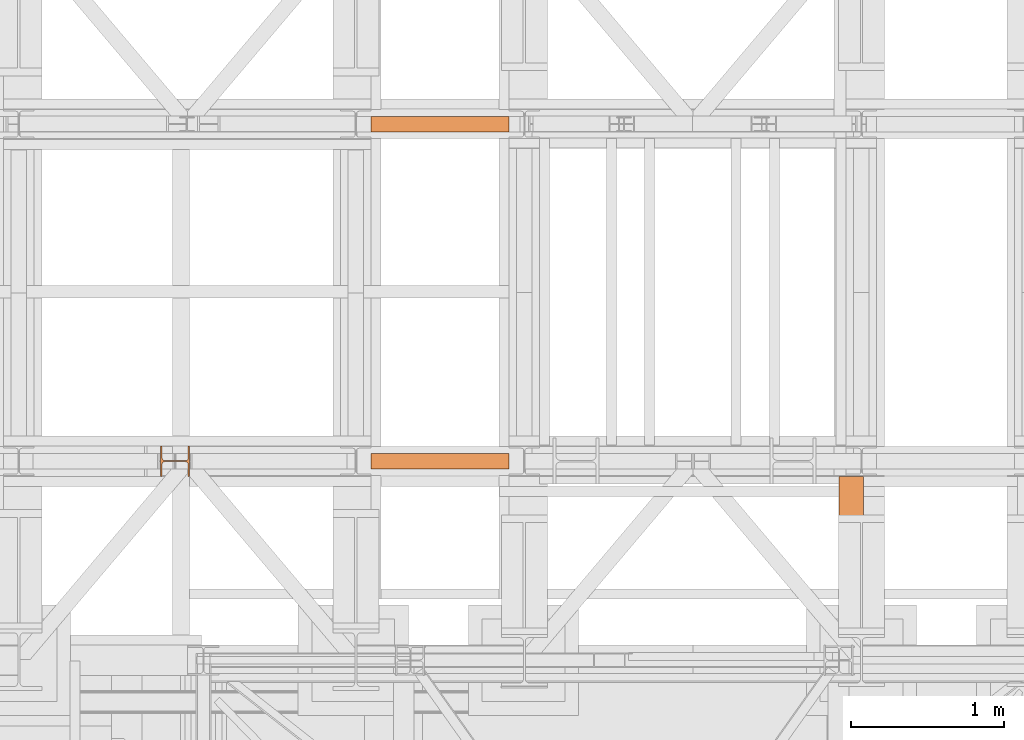
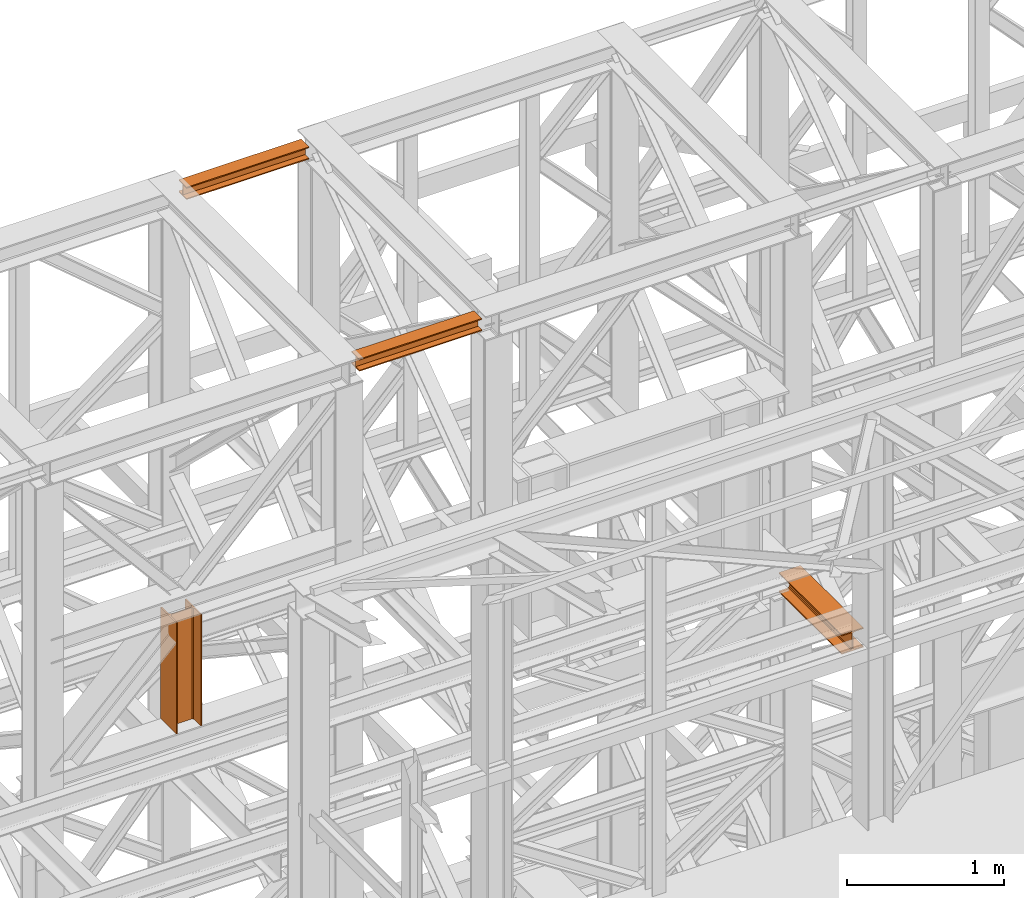
# One storey, part 203 of 208: 4 proxies.
"""IFC2X3 building model written with IfcOpenShell, lengths in millimetres."""

from ifc_helpers import new_model, entity, si_unit, converted_unit, frame, origin, origin_with_axes, place, context, subcontext, project, spatial, faceted_brep, element, save


model = new_model("IFC2X3")

# Units and contexts
model_context = context("Model", 3, precision=1e-05, world=origin())
plan_context = context("Plan", 3, precision=1e-05, world=origin())
body_context = subcontext(model_context, "Body", "Model", "MODEL_VIEW")
ifc_project = project(units=[si_unit("LENGTHUNIT", "METRE", prefix="MILLI"), converted_unit("PLANEANGLEUNIT", "DEGREE", entity("IfcPlaneAngleMeasure", 0.0174532925199433), si_unit("PLANEANGLEUNIT", "RADIAN"), dimensions=[0, 0, 0, 0, 0, 0, 0]), si_unit("AREAUNIT", "SQUARE_METRE"), si_unit("VOLUMEUNIT", "CUBIC_METRE")], contexts=[model_context, plan_context])

# Building, storey
building_placement = place(None, origin())
building = spatial("IfcBuilding", under=ifc_project, at=building_placement, CompositionType="COMPLEX")
storey_placement = place(building_placement, origin_with_axes())
storey = spatial("IfcBuildingStorey", under=building, at=storey_placement, Name="Geschoss", CompositionType="ELEMENT")

# Proxies
proxy_1_placement = place(storey_placement, frame((2293.254970018784, -13812.50587051043, 12300.47045114381), z_axis=(0.0, 0.0, 1.0), x_axis=(1.0, 0.0, 0.0)))
element("IfcBuildingElementProxy", 1, at=proxy_1_placement, inside=storey, context=body_context, shape_type="Brep", body=[
    faceted_brep([(900.009997019768, 0.01000000000021828, 88.01000000000022), (900.009997019768, 0.01000000000021828, 96.01000000000022), (900.009997019768, 100.0100000000002, 96.01000000000022), (900.009997019768, 100.0100000000002, 88.01000000000022), (900.009997019768, 52.51000000000022, 88.01000000000022), (900.009997019768, 52.51000000000022, 8.010000000000218), (900.009997019768, 100.0100000000002, 8.010000000000218), (900.009997019768, 100.0100000000002, 0.01000000000021828), (900.009997019768, 0.01000000000021828, 0.01000000000021828), (900.009997019768, 0.01000000000021828, 8.010000000000218), (900.009997019768, 47.51000000000022, 8.010000000000218), (900.009997019768, 47.51000000000022, 88.01000000000022), (900.009997019768, 0.01000000000021828, 96.01000000000022), (900.009997019768, 0.01000000000021828, 88.01000000000022), (0.01000000000021828, 0.01000000000385626, 88.01000000000022), (0.01000000000021828, 0.01000000000385626, 96.01000000000022), (900.009997019768, 100.0100000000002, 96.01000000000022), (900.009997019768, 0.01000000000021828, 96.01000000000022), (0.01000000000021828, 0.01000000000385626, 96.01000000000022), (0.01000000000021828, 100.0100000000039, 96.01000000000022), (900.009997019768, 100.0100000000002, 88.01000000000022), (900.009997019768, 100.0100000000002, 96.01000000000022), (0.01000000000021828, 100.0100000000039, 96.01000000000022), (0.01000000000021828, 100.0100000000039, 88.01000000000022), (900.009997019768, 52.51000000000022, 88.01000000000022), (900.009997019768, 100.0100000000002, 88.01000000000022), (0.01000000000021828, 100.0100000000039, 88.01000000000022), (0.01000000000021828, 52.51000000000386, 88.01000000000022), (900.009997019768, 52.51000000000022, 8.010000000000218), (900.009997019768, 52.51000000000022, 88.01000000000022), (0.01000000000021828, 52.51000000000386, 88.01000000000022), (0.01000000000021828, 52.51000000000386, 8.010000000000218), (900.009997019768, 100.0100000000002, 8.010000000000218), (900.009997019768, 52.51000000000022, 8.010000000000218), (0.01000000000021828, 52.51000000000386, 8.010000000000218), (0.01000000000021828, 100.0100000000039, 8.010000000000218), (900.009997019768, 100.0100000000002, 0.01000000000021828), (900.009997019768, 100.0100000000002, 8.010000000000218), (0.01000000000021828, 100.0100000000039, 8.010000000000218), (0.01000000000021828, 100.0100000000039, 0.01000000000021828), (900.009997019768, 0.01000000000021828, 0.01000000000021828), (900.009997019768, 100.0100000000002, 0.01000000000021828), (0.01000000000021828, 100.0100000000039, 0.01000000000021828), (0.01000000000021828, 0.01000000000385626, 0.01000000000021828), (900.009997019768, 0.01000000000021828, 8.010000000000218), (900.009997019768, 0.01000000000021828, 0.01000000000021828), (0.01000000000021828, 0.01000000000385626, 0.01000000000021828), (0.01000000000021828, 0.01000000000385626, 8.010000000000218), (900.009997019768, 47.51000000000022, 8.010000000000218), (900.009997019768, 0.01000000000021828, 8.010000000000218), (0.01000000000021828, 0.01000000000385626, 8.010000000000218), (0.01000000000021828, 47.51000000000386, 8.010000000000218), (900.009997019768, 47.51000000000022, 88.01000000000022), (900.009997019768, 47.51000000000022, 8.010000000000218), (0.01000000000021828, 47.51000000000386, 8.010000000000218), (0.01000000000021828, 47.51000000000386, 88.01000000000022), (900.009997019768, 0.01000000000021828, 88.01000000000022), (900.009997019768, 47.51000000000022, 88.01000000000022), (0.01000000000021828, 47.51000000000386, 88.01000000000022), (0.01000000000021828, 0.01000000000385626, 88.01000000000022), (0.01000000000021828, 0.01000000000385626, 88.01000000000022), (0.01000000000021828, 47.51000000000386, 88.01000000000022), (0.01000000000021828, 47.51000000000386, 8.010000000000218), (0.01000000000021828, 0.01000000000385626, 8.010000000000218), (0.01000000000021828, 0.01000000000385626, 0.01000000000021828), (0.01000000000021828, 100.0100000000039, 0.01000000000021828), (0.01000000000021828, 100.0100000000039, 8.010000000000218), (0.01000000000021828, 52.51000000000386, 8.010000000000218), (0.01000000000021828, 52.51000000000386, 88.01000000000022), (0.01000000000021828, 100.0100000000039, 88.01000000000022), (0.01000000000021828, 100.0100000000039, 96.01000000000022), (0.01000000000021828, 0.01000000000385626, 96.01000000000022)], [[[0, 1, 2, 3, 4, 5, 6, 7, 8, 9, 10, 11]], [[12, 13, 14, 15]], [[16, 17, 18, 19]], [[20, 21, 22, 23]], [[24, 25, 26, 27]], [[28, 29, 30, 31]], [[32, 33, 34, 35]], [[36, 37, 38, 39]], [[40, 41, 42, 43]], [[44, 45, 46, 47]], [[48, 49, 50, 51]], [[52, 53, 54, 55]], [[56, 57, 58, 59]], [[60, 61, 62, 63, 64, 65, 66, 67, 68, 69, 70, 71]]], orient=[[False], [False], [False], [False], [False], [False], [False], [False], [False], [False], [False], [False], [False], [False]]),
])
proxy_2_placement = place(storey_placement, frame((918.2549545215736, -16062.574391808, 9993.990046176834), z_axis=(0.0, 0.0, 1.0), x_axis=(1.0, 0.0, 0.0)))
element("IfcBuildingElementProxy", 2, at=proxy_2_placement, inside=storey, context=body_context, shape_type="Brep", body=[
    faceted_brep([(190.0100125169754, 0.01000000000021828, 0.01000000000021828), (190.0100125169754, 200.0100029802325, 0.01000000000021828), (180.010014603138, 200.0100029802325, 0.01000000000021828), (180.0100071525574, 121.2600035762789, 0.01000000000021828), (178.1454621052742, 111.9441915473344, 0.01000000000021828), (171.3258190250397, 105.1245498640838, 0.01000000000021828), (162.0100079274178, 103.2600015571716, 0.01000000000021828), (28.00999713897704, 103.2600015571716, 0.01000000000021828), (18.69418604135512, 105.1245498640838, 0.01000000000021828), (11.8745429611206, 111.9441915473344, 0.01000000000021828), (10.00999791383742, 121.2600035762789, 0.01000000000021828), (10.00999791383742, 200.0100029802325, 0.01000000000021828), (0.009999999999990905, 200.0100029802325, 0.01000000000021828), (0.009999999999990905, 0.01000000000021828, 0.01000000000021828), (10.00999791383742, 0.01000000000021828, 0.01000000000021828), (10.00999791383742, 78.75999940395377, 0.01000000000021828), (11.8745429611206, 88.07581143289826, 0.01000000000021828), (18.69418604135512, 94.89545311614893, 0.01000000000021828), (28.00999713897704, 96.76000142306111, 0.01000000000021828), (162.0100079274178, 96.76000142306111, 0.01000000000021828), (171.3258190250397, 94.89545311614893, 0.01000000000021828), (178.1454621052742, 88.07581143289826, 0.01000000000021828), (180.0100071525574, 78.75999940395377, 0.01000000000021828), (180.010014603138, 0.01000000000021828, 0.01000000000021828), (190.0100125169754, 200.0100029802325, 0.01000000000021828), (190.0100125169754, 0.01000000000021828, 0.01000000000021828), (190.0100125169754, 0.01000000000021828, 865.0100000000002), (190.0100125169754, 200.0100029802325, 865.0100000000002), (180.010014603138, 200.0100029802325, 0.01000000000021828), (190.0100125169754, 200.0100029802325, 0.01000000000021828), (190.0100125169754, 200.0100029802325, 865.0100000000002), (180.010014603138, 200.0100029802325, 865.0100000000002), (180.0100071525574, 121.2600035762789, 0.01000000000021828), (180.010014603138, 200.0100029802325, 0.01000000000021828), (180.010014603138, 200.0100029802325, 865.0100000000002), (180.0100071525574, 121.2600035762789, 865.0100000000002), (178.1454621052742, 111.9441915473344, 0.01000000000021828), (180.0100071525574, 121.2600035762789, 0.01000000000021828), (180.0100071525574, 121.2600035762789, 865.0100000000002), (178.1454621052742, 111.9441915473344, 865.0100000000002), (171.3258190250397, 105.1245498640838, 0.01000000000021828), (178.1454621052742, 111.9441915473344, 0.01000000000021828), (178.1454621052742, 111.9441915473344, 865.0100000000002), (171.3258190250397, 105.1245498640838, 865.0100000000002), (162.0100079274178, 103.2600015571716, 0.01000000000021828), (171.3258190250397, 105.1245498640838, 0.01000000000021828), (171.3258190250397, 105.1245498640838, 865.0100000000002), (162.0100079274178, 103.2600015571716, 865.0100000000002), (28.00999713897704, 103.2600015571716, 0.01000000000021828), (162.0100079274178, 103.2600015571716, 0.01000000000021828), (162.0100079274178, 103.2600015571716, 865.0100000000002), (28.00999713897704, 103.2600015571716, 865.0100000000002), (18.69418604135512, 105.1245498640838, 0.01000000000021828), (28.00999713897704, 103.2600015571716, 0.01000000000021828), (28.00999713897704, 103.2600015571716, 865.0100000000002), (18.69418604135512, 105.1245498640838, 865.0100000000002), (11.8745429611206, 111.9441915473344, 0.01000000000021828), (18.69418604135512, 105.1245498640838, 0.01000000000021828), (18.69418604135512, 105.1245498640838, 865.0100000000002), (11.8745429611206, 111.9441915473344, 865.0100000000002), (10.00999791383742, 121.2600035762789, 0.01000000000021828), (11.8745429611206, 111.9441915473344, 0.01000000000021828), (11.8745429611206, 111.9441915473344, 865.0100000000002), (10.00999791383742, 121.2600035762789, 865.0100000000002), (10.00999791383742, 200.0100029802325, 0.01000000000021828), (10.00999791383742, 121.2600035762789, 0.01000000000021828), (10.00999791383742, 121.2600035762789, 865.0100000000002), (10.00999791383742, 200.0100029802325, 865.0100000000002), (0.009999999999990905, 200.0100029802325, 0.01000000000021828), (10.00999791383742, 200.0100029802325, 0.01000000000021828), (10.00999791383742, 200.0100029802325, 865.0100000000002), (0.009999999999990905, 200.0100029802325, 865.0100000000002), (0.009999999999990905, 0.01000000000021828, 0.01000000000021828), (0.009999999999990905, 200.0100029802325, 0.01000000000021828), (0.009999999999990905, 200.0100029802325, 865.0100000000002), (0.009999999999990905, 0.01000000000021828, 865.0100000000002), (10.00999791383742, 0.01000000000021828, 0.01000000000021828), (0.009999999999990905, 0.01000000000021828, 0.01000000000021828), (0.009999999999990905, 0.01000000000021828, 865.0100000000002), (10.00999791383742, 0.01000000000021828, 865.0100000000002), (10.00999791383742, 78.75999940395377, 0.01000000000021828), (10.00999791383742, 0.01000000000021828, 0.01000000000021828), (10.00999791383742, 0.01000000000021828, 865.0100000000002), (10.00999791383742, 78.75999940395377, 865.0100000000002), (11.8745429611206, 88.07581143289826, 0.01000000000021828), (10.00999791383742, 78.75999940395377, 0.01000000000021828), (10.00999791383742, 78.75999940395377, 865.0100000000002), (11.8745429611206, 88.07581143289826, 865.0100000000002), (18.69418604135512, 94.89545311614893, 0.01000000000021828), (11.8745429611206, 88.07581143289826, 0.01000000000021828), (11.8745429611206, 88.07581143289826, 865.0100000000002), (18.69418604135512, 94.89545311614893, 865.0100000000002), (28.00999713897704, 96.76000142306111, 0.01000000000021828), (18.69418604135512, 94.89545311614893, 0.01000000000021828), (18.69418604135512, 94.89545311614893, 865.0100000000002), (28.00999713897704, 96.76000142306111, 865.0100000000002), (162.0100079274178, 96.76000142306111, 0.01000000000021828), (28.00999713897704, 96.76000142306111, 0.01000000000021828), (28.00999713897704, 96.76000142306111, 865.0100000000002), (162.0100079274178, 96.76000142306111, 865.0100000000002), (171.3258190250397, 94.89545311614893, 0.01000000000021828), (162.0100079274178, 96.76000142306111, 0.01000000000021828), (162.0100079274178, 96.76000142306111, 865.0100000000002), (171.3258190250397, 94.89545311614893, 865.0100000000002), (178.1454621052742, 88.07581143289826, 0.01000000000021828), (171.3258190250397, 94.89545311614893, 0.01000000000021828), (171.3258190250397, 94.89545311614893, 865.0100000000002), (178.1454621052742, 88.07581143289826, 865.0100000000002), (180.0100071525574, 78.75999940395377, 0.01000000000021828), (178.1454621052742, 88.07581143289826, 0.01000000000021828), (178.1454621052742, 88.07581143289826, 865.0100000000002), (180.0100071525574, 78.75999940395377, 865.0100000000002), (180.010014603138, 0.01000000000021828, 0.01000000000021828), (180.0100071525574, 78.75999940395377, 0.01000000000021828), (180.0100071525574, 78.75999940395377, 865.0100000000002), (180.010014603138, 0.01000000000021828, 865.0100000000002), (190.0100125169754, 0.01000000000021828, 0.01000000000021828), (180.010014603138, 0.01000000000021828, 0.01000000000021828), (180.010014603138, 0.01000000000021828, 865.0100000000002), (190.0100125169754, 0.01000000000021828, 865.0100000000002), (190.0100125169754, 0.01000000000021828, 865.0100000000002), (180.010014603138, 0.01000000000021828, 865.0100000000002), (180.0100071525574, 78.75999940395377, 865.0100000000002), (178.1454621052742, 88.07581143289826, 865.0100000000002), (171.3258190250397, 94.89545311614893, 865.0100000000002), (162.0100079274178, 96.76000142306111, 865.0100000000002), (28.00999713897704, 96.76000142306111, 865.0100000000002), (18.69418604135512, 94.89545311614893, 865.0100000000002), (11.8745429611206, 88.07581143289826, 865.0100000000002), (10.00999791383742, 78.75999940395377, 865.0100000000002), (10.00999791383742, 0.01000000000021828, 865.0100000000002), (0.009999999999990905, 0.01000000000021828, 865.0100000000002), (0.009999999999990905, 200.0100029802325, 865.0100000000002), (10.00999791383742, 200.0100029802325, 865.0100000000002), (10.00999791383742, 121.2600035762789, 865.0100000000002), (11.8745429611206, 111.9441915473344, 865.0100000000002), (18.69418604135512, 105.1245498640838, 865.0100000000002), (28.00999713897704, 103.2600015571716, 865.0100000000002), (162.0100079274178, 103.2600015571716, 865.0100000000002), (171.3258190250397, 105.1245498640838, 865.0100000000002), (178.1454621052742, 111.9441915473344, 865.0100000000002), (180.0100071525574, 121.2600035762789, 865.0100000000002), (180.010014603138, 200.0100029802325, 865.0100000000002), (190.0100125169754, 200.0100029802325, 865.0100000000002)], [[[0, 1, 2, 3, 4, 5, 6, 7, 8, 9, 10, 11, 12, 13, 14, 15, 16, 17, 18, 19, 20, 21, 22, 23]], [[24, 25, 26, 27]], [[28, 29, 30, 31]], [[32, 33, 34, 35]], [[36, 37, 38, 39]], [[40, 41, 42, 43]], [[44, 45, 46, 47]], [[48, 49, 50, 51]], [[52, 53, 54, 55]], [[56, 57, 58, 59]], [[60, 61, 62, 63]], [[64, 65, 66, 67]], [[68, 69, 70, 71]], [[72, 73, 74, 75]], [[76, 77, 78, 79]], [[80, 81, 82, 83]], [[84, 85, 86, 87]], [[88, 89, 90, 91]], [[92, 93, 94, 95]], [[96, 97, 98, 99]], [[100, 101, 102, 103]], [[104, 105, 106, 107]], [[108, 109, 110, 111]], [[112, 113, 114, 115]], [[116, 117, 118, 119]], [[120, 121, 122, 123, 124, 125, 126, 127, 128, 129, 130, 131, 132, 133, 134, 135, 136, 137, 138, 139, 140, 141, 142, 143]]], orient=[[False], [False], [False], [False], [False], [False], [False], [False], [False], [False], [False], [False], [False], [False], [False], [False], [False], [False], [False], [False], [False], [False], [False], [False], [False], [False]]),
])
proxy_3_placement = place(storey_placement, frame((2293.254970018784, -16012.50587051043, 12300.47045114381), z_axis=(0.0, 0.0, 1.0), x_axis=(1.0, 0.0, 0.0)))
element("IfcBuildingElementProxy", 3, at=proxy_3_placement, inside=storey, context=body_context, shape_type="Brep", body=[
    faceted_brep([(900.009997019768, 0.01000000000021828, 88.01000000000022), (900.009997019768, 0.01000000000021828, 96.01000000000022), (900.009997019768, 100.0100000000002, 96.01000000000022), (900.009997019768, 100.0100000000002, 88.01000000000022), (900.009997019768, 52.51000000000022, 88.01000000000022), (900.009997019768, 52.51000000000022, 8.010000000000218), (900.009997019768, 100.0100000000002, 8.010000000000218), (900.009997019768, 100.0100000000002, 0.01000000000021828), (900.009997019768, 0.01000000000021828, 0.01000000000021828), (900.009997019768, 0.01000000000021828, 8.010000000000218), (900.009997019768, 47.51000000000022, 8.010000000000218), (900.009997019768, 47.51000000000022, 88.01000000000022), (900.009997019768, 0.01000000000021828, 96.01000000000022), (900.009997019768, 0.01000000000021828, 88.01000000000022), (0.01000000000021828, 0.01000000000385626, 88.01000000000022), (0.01000000000021828, 0.01000000000385626, 96.01000000000022), (900.009997019768, 100.0100000000002, 96.01000000000022), (900.009997019768, 0.01000000000021828, 96.01000000000022), (0.01000000000021828, 0.01000000000385626, 96.01000000000022), (0.01000000000021828, 100.0100000000039, 96.01000000000022), (900.009997019768, 100.0100000000002, 88.01000000000022), (900.009997019768, 100.0100000000002, 96.01000000000022), (0.01000000000021828, 100.0100000000039, 96.01000000000022), (0.01000000000021828, 100.0100000000039, 88.01000000000022), (900.009997019768, 52.51000000000022, 88.01000000000022), (900.009997019768, 100.0100000000002, 88.01000000000022), (0.01000000000021828, 100.0100000000039, 88.01000000000022), (0.01000000000021828, 52.51000000000386, 88.01000000000022), (900.009997019768, 52.51000000000022, 8.010000000000218), (900.009997019768, 52.51000000000022, 88.01000000000022), (0.01000000000021828, 52.51000000000386, 88.01000000000022), (0.01000000000021828, 52.51000000000386, 8.010000000000218), (900.009997019768, 100.0100000000002, 8.010000000000218), (900.009997019768, 52.51000000000022, 8.010000000000218), (0.01000000000021828, 52.51000000000386, 8.010000000000218), (0.01000000000021828, 100.0100000000039, 8.010000000000218), (900.009997019768, 100.0100000000002, 0.01000000000021828), (900.009997019768, 100.0100000000002, 8.010000000000218), (0.01000000000021828, 100.0100000000039, 8.010000000000218), (0.01000000000021828, 100.0100000000039, 0.01000000000021828), (900.009997019768, 0.01000000000021828, 0.01000000000021828), (900.009997019768, 100.0100000000002, 0.01000000000021828), (0.01000000000021828, 100.0100000000039, 0.01000000000021828), (0.01000000000021828, 0.01000000000385626, 0.01000000000021828), (900.009997019768, 0.01000000000021828, 8.010000000000218), (900.009997019768, 0.01000000000021828, 0.01000000000021828), (0.01000000000021828, 0.01000000000385626, 0.01000000000021828), (0.01000000000021828, 0.01000000000385626, 8.010000000000218), (900.009997019768, 47.51000000000022, 8.010000000000218), (900.009997019768, 0.01000000000021828, 8.010000000000218), (0.01000000000021828, 0.01000000000385626, 8.010000000000218), (0.01000000000021828, 47.51000000000386, 8.010000000000218), (900.009997019768, 47.51000000000022, 88.01000000000022), (900.009997019768, 47.51000000000022, 8.010000000000218), (0.01000000000021828, 47.51000000000386, 8.010000000000218), (0.01000000000021828, 47.51000000000386, 88.01000000000022), (900.009997019768, 0.01000000000021828, 88.01000000000022), (900.009997019768, 47.51000000000022, 88.01000000000022), (0.01000000000021828, 47.51000000000386, 88.01000000000022), (0.01000000000021828, 0.01000000000385626, 88.01000000000022), (0.01000000000021828, 0.01000000000385626, 88.01000000000022), (0.01000000000021828, 47.51000000000386, 88.01000000000022), (0.01000000000021828, 47.51000000000386, 8.010000000000218), (0.01000000000021828, 0.01000000000385626, 8.010000000000218), (0.01000000000021828, 0.01000000000385626, 0.01000000000021828), (0.01000000000021828, 100.0100000000039, 0.01000000000021828), (0.01000000000021828, 100.0100000000039, 8.010000000000218), (0.01000000000021828, 52.51000000000386, 8.010000000000218), (0.01000000000021828, 52.51000000000386, 88.01000000000022), (0.01000000000021828, 100.0100000000039, 88.01000000000022), (0.01000000000021828, 100.0100000000039, 96.01000000000022), (0.01000000000021828, 0.01000000000385626, 96.01000000000022)], [[[0, 1, 2, 3, 4, 5, 6, 7, 8, 9, 10, 11]], [[12, 13, 14, 15]], [[16, 17, 18, 19]], [[20, 21, 22, 23]], [[24, 25, 26, 27]], [[28, 29, 30, 31]], [[32, 33, 34, 35]], [[36, 37, 38, 39]], [[40, 41, 42, 43]], [[44, 45, 46, 47]], [[48, 49, 50, 51]], [[52, 53, 54, 55]], [[56, 57, 58, 59]], [[60, 61, 62, 63, 64, 65, 66, 67, 68, 69, 70, 71]]], orient=[[False], [False], [False], [False], [False], [False], [False], [False], [False], [False], [False], [False], [False], [False]]),
])
proxy_4_placement = place(storey_placement, frame((5346.431540166703, -16862.57439180801, 9547.98998998642), z_axis=(0.0, 0.0, 1.0), x_axis=(1.0, 0.0, 0.0)))
element("IfcBuildingElementProxy", 4, at=proxy_4_placement, inside=storey, context=body_context, shape_type="Brep", body=[
    faceted_brep([(160.0100113248827, 0.00999999999839929, 0.01000000000021828), (0.01000000000021828, 0.00999999999839929, 0.01000000000021828), (0.01000000000021828, 0.00999999999839929, 9.010003337860326), (62.01000457465671, 0.00999999999839929, 9.010003337860326), (69.7731807997825, 0.00999999999839929, 10.5637921190264), (75.4562154582145, 0.00999999999839929, 16.24682677745841), (77.01000563636444, 0.00999999999839929, 24.01000020861648), (77.01000563636444, 0.00999999999839929, 128.010006079674), (75.4562154582145, 0.00999999999839929, 135.7731832361224), (69.7731807997825, 0.00999999999839929, 141.4562178945544), (62.01000457465671, 0.00999999999839929, 143.0100066757204), (0.01000000000021828, 0.00999999999839929, 143.0100066757204), (0.01000000000021828, 0.00999999999839929, 152.0100100135805), (160.0100113248827, 0.00999999999839929, 152.0100100135805), (160.0100113248827, 0.00999999999839929, 143.0100066757204), (98.01000675022624, 0.00999999999839929, 143.0100066757204), (90.24683052510045, 0.00999999999839929, 141.4562178945544), (84.56379586666844, 0.00999999999839929, 135.7731832361224), (83.0100056885185, 0.00999999999839929, 128.010006079674), (83.0100056885185, 0.00999999999839929, 24.01000020861648), (84.56379586666844, 0.00999999999839929, 16.24682677745841), (90.24683052510045, 0.00999999999839929, 10.5637921190264), (98.01000675022624, 0.00999999999839929, 9.010003337860326), (160.0100113248827, 0.00999999999839929, 9.010003337860326), (0.01000000000021828, 0.00999999999839929, 0.01000000000021828), (160.0100113248827, 0.00999999999839929, 0.01000000000021828), (160.0100113248791, 800.0100000000039, 0.01000000000021828), (0.01000000000021828, 800.0100000000039, 0.01000000000021828), (0.01000000000021828, 0.00999999999839929, 9.010003337860326), (0.01000000000021828, 0.00999999999839929, 0.01000000000021828), (0.01000000000021828, 800.0100000000039, 0.01000000000021828), (0.01000000000021828, 800.0100000000039, 9.010003337860326), (62.01000457465671, 0.00999999999839929, 9.010003337860326), (0.01000000000021828, 0.00999999999839929, 9.010003337860326), (0.01000000000021828, 800.0100000000039, 9.010003337860326), (62.01000457465671, 800.0100000000039, 9.010003337860326), (69.7731807997825, 0.00999999999839929, 10.5637921190264), (62.01000457465671, 0.00999999999839929, 9.010003337860326), (62.01000457465671, 800.0100000000039, 9.010003337860326), (69.77318079977886, 800.0100000000039, 10.5637921190264), (75.4562154582145, 0.00999999999839929, 16.24682677745841), (69.7731807997825, 0.00999999999839929, 10.5637921190264), (69.77318079977886, 800.0100000000039, 10.5637921190264), (75.45621545821086, 800.0100000000039, 16.24682677745841), (77.01000563636444, 0.00999999999839929, 24.01000020861648), (75.4562154582145, 0.00999999999839929, 16.24682677745841), (75.45621545821086, 800.0100000000039, 16.24682677745841), (77.0100056363608, 800.0100000000039, 24.01000020861648), (77.01000563636444, 0.00999999999839929, 128.010006079674), (77.01000563636444, 0.00999999999839929, 24.01000020861648), (77.0100056363608, 800.0100000000039, 24.01000020861648), (77.0100056363608, 800.0100000000039, 128.010006079674), (75.4562154582145, 0.00999999999839929, 135.7731832361224), (77.01000563636444, 0.00999999999839929, 128.010006079674), (77.0100056363608, 800.0100000000039, 128.010006079674), (75.45621545821086, 800.0100000000039, 135.7731832361224), (69.7731807997825, 0.00999999999839929, 141.4562178945544), (75.4562154582145, 0.00999999999839929, 135.7731832361224), (75.45621545821086, 800.0100000000039, 135.7731832361224), (69.77318079977886, 800.0100000000039, 141.4562178945544), (62.01000457465671, 0.00999999999839929, 143.0100066757204), (69.7731807997825, 0.00999999999839929, 141.4562178945544), (69.77318079977886, 800.0100000000039, 141.4562178945544), (62.01000457465307, 800.0100000000039, 143.0100066757204), (0.01000000000021828, 0.00999999999839929, 143.0100066757204), (62.01000457465671, 0.00999999999839929, 143.0100066757204), (62.01000457465307, 800.0100000000039, 143.0100066757204), (0.01000000000021828, 800.0100000000039, 143.0100066757204), (0.01000000000021828, 0.00999999999839929, 152.0100100135805), (0.01000000000021828, 0.00999999999839929, 143.0100066757204), (0.01000000000021828, 800.0100000000039, 143.0100066757204), (0.01000000000021828, 800.0100000000039, 152.0100100135805), (160.0100113248827, 0.00999999999839929, 152.0100100135805), (0.01000000000021828, 0.00999999999839929, 152.0100100135805), (0.01000000000021828, 800.0100000000039, 152.0100100135805), (160.0100113248827, 800.0100000000039, 152.0100100135842), (160.0100113248827, 0.00999999999839929, 143.0100066757204), (160.0100113248827, 0.00999999999839929, 152.0100100135805), (160.0100113248827, 800.0100000000039, 152.0100100135842), (160.0100113248827, 800.0100000000039, 143.0100066757204), (98.01000675022624, 0.00999999999839929, 143.0100066757204), (160.0100113248827, 0.00999999999839929, 143.0100066757204), (160.0100113248827, 800.0100000000039, 143.0100066757204), (98.0100067502226, 800.0100000000039, 143.0100066757204), (90.24683052510045, 0.00999999999839929, 141.4562178945544), (98.01000675022624, 0.00999999999839929, 143.0100066757204), (98.0100067502226, 800.0100000000039, 143.0100066757204), (90.24683052509681, 800.0100000000039, 141.4562178945544), (84.56379586666844, 0.00999999999839929, 135.7731832361224), (90.24683052510045, 0.00999999999839929, 141.4562178945544), (90.24683052509681, 800.0100000000039, 141.4562178945544), (84.5637958666648, 800.0100000000039, 135.773183236126), (83.0100056885185, 0.00999999999839929, 128.010006079674), (84.56379586666844, 0.00999999999839929, 135.7731832361224), (84.5637958666648, 800.0100000000039, 135.773183236126), (83.01000568851487, 800.0100000000039, 128.0100060796776), (83.0100056885185, 0.00999999999839929, 24.01000020861648), (83.0100056885185, 0.00999999999839929, 128.010006079674), (83.01000568851487, 800.0100000000039, 128.0100060796776), (83.01000568851487, 800.0100000000039, 24.01000020861648), (84.56379586666844, 0.00999999999839929, 16.24682677745841), (83.0100056885185, 0.00999999999839929, 24.01000020861648), (83.01000568851487, 800.0100000000039, 24.01000020861648), (84.5637958666648, 800.0100000000039, 16.24682677745841), (90.24683052510045, 0.00999999999839929, 10.5637921190264), (84.56379586666844, 0.00999999999839929, 16.24682677745841), (84.5637958666648, 800.0100000000039, 16.24682677745841), (90.24683052509681, 800.0100000000039, 10.5637921190264), (98.01000675022624, 0.00999999999839929, 9.010003337860326), (90.24683052510045, 0.00999999999839929, 10.5637921190264), (90.24683052509681, 800.0100000000039, 10.5637921190264), (98.0100067502226, 800.0100000000039, 9.010003337860326), (160.0100113248827, 0.00999999999839929, 9.010003337860326), (98.01000675022624, 0.00999999999839929, 9.010003337860326), (98.0100067502226, 800.0100000000039, 9.010003337860326), (160.0100113248827, 800.0100000000039, 9.010003337860326), (160.0100113248827, 0.00999999999839929, 0.01000000000021828), (160.0100113248827, 0.00999999999839929, 9.010003337860326), (160.0100113248827, 800.0100000000039, 9.010003337860326), (160.0100113248791, 800.0100000000039, 0.01000000000021828), (160.0100113248791, 800.0100000000039, 0.01000000000021828), (160.0100113248827, 800.0100000000039, 9.010003337860326), (98.0100067502226, 800.0100000000039, 9.010003337860326), (90.24683052509681, 800.0100000000039, 10.5637921190264), (84.5637958666648, 800.0100000000039, 16.24682677745841), (83.01000568851487, 800.0100000000039, 24.01000020861648), (83.01000568851487, 800.0100000000039, 128.0100060796776), (84.5637958666648, 800.0100000000039, 135.773183236126), (90.24683052509681, 800.0100000000039, 141.4562178945544), (98.0100067502226, 800.0100000000039, 143.0100066757204), (160.0100113248827, 800.0100000000039, 143.0100066757204), (160.0100113248827, 800.0100000000039, 152.0100100135842), (0.01000000000021828, 800.0100000000039, 152.0100100135805), (0.01000000000021828, 800.0100000000039, 143.0100066757204), (62.01000457465307, 800.0100000000039, 143.0100066757204), (69.77318079977886, 800.0100000000039, 141.4562178945544), (75.45621545821086, 800.0100000000039, 135.7731832361224), (77.0100056363608, 800.0100000000039, 128.010006079674), (77.0100056363608, 800.0100000000039, 24.01000020861648), (75.45621545821086, 800.0100000000039, 16.24682677745841), (69.77318079977886, 800.0100000000039, 10.5637921190264), (62.01000457465671, 800.0100000000039, 9.010003337860326), (0.01000000000021828, 800.0100000000039, 9.010003337860326), (0.01000000000021828, 800.0100000000039, 0.01000000000021828)], [[[0, 1, 2, 3, 4, 5, 6, 7, 8, 9, 10, 11, 12, 13, 14, 15, 16, 17, 18, 19, 20, 21, 22, 23]], [[24, 25, 26, 27]], [[28, 29, 30, 31]], [[32, 33, 34, 35]], [[36, 37, 38, 39]], [[40, 41, 42, 43]], [[44, 45, 46, 47]], [[48, 49, 50, 51]], [[52, 53, 54, 55]], [[56, 57, 58, 59]], [[60, 61, 62, 63]], [[64, 65, 66, 67]], [[68, 69, 70, 71]], [[72, 73, 74, 75]], [[76, 77, 78, 79]], [[80, 81, 82, 83]], [[84, 85, 86, 87]], [[88, 89, 90, 91]], [[92, 93, 94, 95]], [[96, 97, 98, 99]], [[100, 101, 102, 103]], [[104, 105, 106, 107]], [[108, 109, 110, 111]], [[112, 113, 114, 115]], [[116, 117, 118, 119]], [[120, 121, 122, 123, 124, 125, 126, 127, 128, 129, 130, 131, 132, 133, 134, 135, 136, 137, 138, 139, 140, 141, 142, 143]]], orient=[[False], [False], [False], [False], [False], [False], [False], [False], [False], [False], [False], [False], [False], [False], [False], [False], [False], [False], [False], [False], [False], [False], [False], [False], [False], [False]]),
])

save(model, "model.ifc")
